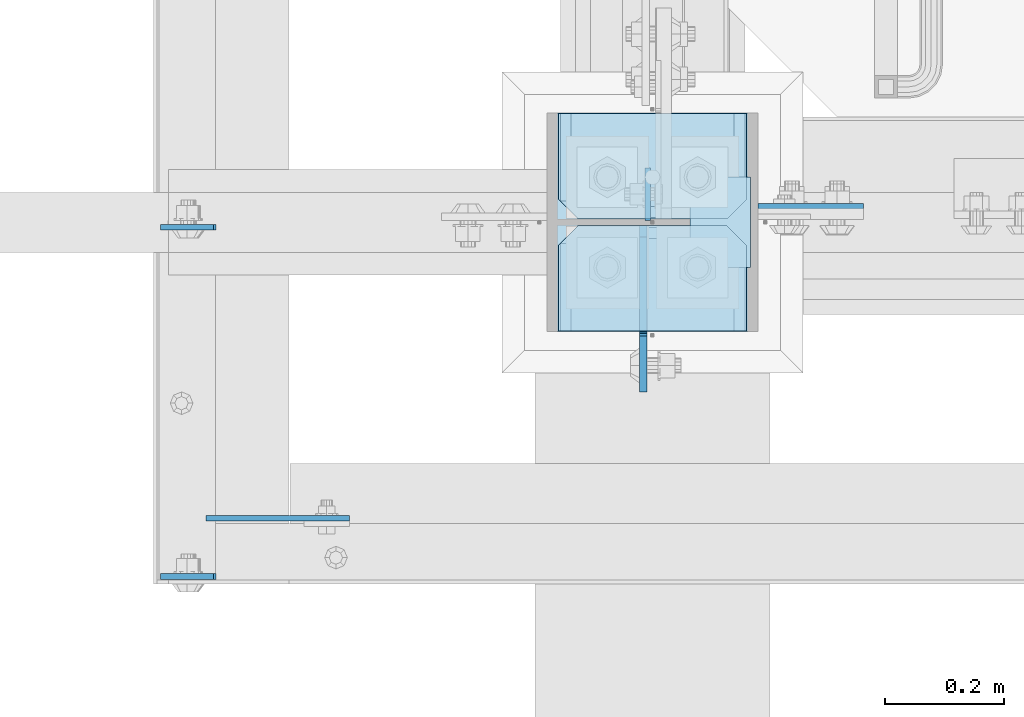
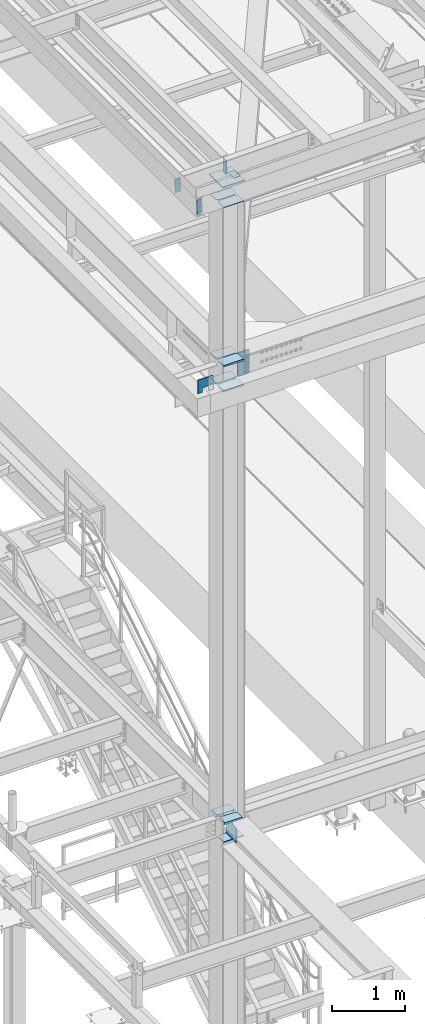
# One storey, part 3018 of 3843: 17 plates, 4 elements without a shape of their own.
"""IFC2X3 building model written with IfcOpenShell, lengths in millimetres."""

from ifc_helpers import new_model, si_unit, frame, origin_with_axes, place, context, subcontext, project, spatial, faceted_brep, material, type_object, element, aggregate, save


model = new_model("IFC2X3")

# Units and contexts
model_context = context("Model", 3, precision=1e-05, world=origin_with_axes())
body_context = subcontext(model_context, "Body", "Model", "MODEL_VIEW")
ifc_project = project(units=[si_unit("LENGTHUNIT", "METRE", prefix="MILLI"), si_unit("AREAUNIT", "SQUARE_METRE"), si_unit("VOLUMEUNIT", "CUBIC_METRE"), si_unit("MASSUNIT", "GRAM", prefix="KILO"), si_unit("TIMEUNIT", "SECOND"), si_unit("PLANEANGLEUNIT", "RADIAN"), si_unit("SOLIDANGLEUNIT", "STERADIAN"), si_unit("THERMODYNAMICTEMPERATUREUNIT", "DEGREE_CELSIUS"), si_unit("LUMINOUSINTENSITYUNIT", "LUMEN")], contexts=[model_context])

# Site, building, storey
site_placement = place(None, origin_with_axes())
site = spatial("IfcSite", under=ifc_project, at=site_placement, CompositionType="ELEMENT")
building_placement = place(site_placement, origin_with_axes())
building = spatial("IfcBuilding", under=site, at=building_placement, Name="Undefined", CompositionType="ELEMENT")
storey_placement = place(building_placement, origin_with_axes())
storey = spatial("IfcBuildingStorey", under=building, at=storey_placement, Name="Undefined", CompositionType="ELEMENT", Elevation=0.0)

# Assembly, plates
assembly_1_placement = place(storey_placement, origin_with_axes())
assembly_1 = element("IfcElementAssembly", 1, at=assembly_1_placement, inside=storey, Name="COLUMN", AssemblyPlace="NOTDEFINED", PredefinedType="RIGID_FRAME")
ifc_material = material(Name="STEEL/A572-50")
plate_type_1 = type_object("IfcPlateType", PredefinedType="NOTDEFINED")
plate_1_placement = place(assembly_1_placement, frame((36734.75, 25610.34375, 34493.2), z_axis=(-1.0, 0.0, 0.0), x_axis=(0.0, -1.0, 0.0)))
plate_1 = element("IfcPlate", 2, at=plate_1_placement, type_object=plate_type_1, material=ifc_material, Name="PLATE", context=body_context, shape_type="Brep", body=[
    faceted_brep([(0.0, -6.34999999999854, 33.3375015258789), (0.0, -6.34999999999854, 284.162498474121), (0.0, 6.34999999999854, 284.162498474121), (0.0, 6.34999999999854, 33.3375015258789), (33.3375015258789, -6.34999999999854, 317.5), (33.3375015258789, 6.34999999999854, 317.5), (177.800003051758, -6.34999999999854, 317.5), (177.800003051758, 6.34999999999854, 317.5), (177.800000000003, -6.34999999999854, 0.0), (177.800000000003, 6.34999999999854, 0.0), (33.3375015258789, -6.34999999999854, 0.0), (33.3375015258789, 6.34999999999854, 0.0)], [[[0, 1, 2, 3]], [[1, 4, 5, 2]], [[4, 6, 7, 5]], [[6, 8, 9, 7]], [[8, 10, 11, 9]], [[10, 0, 3, 11]], [[5, 7, 9, 11, 3, 2]], [[10, 8, 6, 4, 1, 0]]]),
])
plate_type_2 = type_object("IfcPlateType", PredefinedType="NOTDEFINED")
plate_2_placement = place(assembly_1_placement, frame((36734.75, 25610.34375, 42005.249987793), z_axis=(-1.0, 0.0, 0.0), x_axis=(0.0, -1.0, 0.0)))
plate_2 = element("IfcPlate", 3, at=plate_2_placement, type_object=plate_type_2, material=ifc_material, Name="PLATE", context=body_context, shape_type="Brep", body=[
    faceted_brep([(0.0, -12.6999999999971, 33.3375015258789), (0.0, -12.6999999999971, 284.162498474121), (0.0, 12.6999999999971, 284.162498474121), (0.0, 12.6999999999971, 33.3375015258789), (33.3375015258789, -12.6999999999971, 317.5), (33.3375015258789, 12.6999999999971, 317.5), (177.800003051758, -12.6999999999971, 317.5), (177.800003051758, 12.6999999999971, 317.5), (177.800003051758, -12.6999999999971, 0.0), (177.800003051758, 12.6999999999971, 0.0), (33.3375015258789, -12.6999999999971, 0.0), (33.3375015258789, 12.6999999999971, 0.0)], [[[0, 1, 2, 3]], [[1, 4, 5, 2]], [[4, 6, 7, 5]], [[6, 8, 9, 7]], [[8, 10, 11, 9]], [[10, 0, 3, 11]], [[5, 7, 9, 11, 3, 2]], [[10, 8, 6, 4, 1, 0]]]),
])
plate_3_placement = place(assembly_1_placement, frame((36734.75, 25610.34375, 42424.35), z_axis=(-1.0, 0.0, 0.0), x_axis=(0.0, -1.0, 0.0)))
plate_3 = element("IfcPlate", 4, at=plate_3_placement, type_object=plate_type_2, material=ifc_material, Name="PLATE", context=body_context, shape_type="Brep", body=[
    faceted_brep([(0.0, -12.6999999999971, 33.3375015258789), (0.0, -12.6999999999971, 284.162498474121), (0.0, 12.6999999999971, 284.162498474121), (0.0, 12.6999999999971, 33.3375015258789), (33.3375015258789, -12.6999999999971, 317.5), (33.3375015258789, 12.6999999999971, 317.5), (177.800003051758, -12.6999999999971, 317.5), (177.800003051758, 12.6999999999971, 317.5), (177.800003051758, -12.6999999999971, 0.0), (177.800003051758, 12.6999999999971, 0.0), (33.3375015258789, -12.6999999999971, 0.0), (33.3375015258789, 12.6999999999971, 0.0)], [[[0, 1, 2, 3]], [[1, 4, 5, 2]], [[4, 6, 7, 5]], [[6, 8, 9, 7]], [[8, 10, 11, 9]], [[10, 0, 3, 11]], [[5, 7, 9, 11, 3, 2]], [[10, 8, 6, 4, 1, 0]]]),
])
plate_4_placement = place(assembly_1_placement, frame((36753.8, 25634.95, 42411.65), z_axis=(1.0, 0.0, 0.0), x_axis=(0.0, 0.0, -1.0)))
plate_4 = element("IfcPlate", 5, at=plate_4_placement, type_object=plate_type_2, material=ifc_material, Name="PLATE", context=body_context, shape_type="Brep", body=[
    faceted_brep([(0.0, -12.6999999999971, 0.0), (4.36557456851006e-11, -12.7000000000171, 177.800000000003), (-1.45519152283669e-11, 12.7000000000025, 177.800000000003), (0.0, 12.6999999999971, 0.0), (393.700012207031, -12.7000000000007, 177.800003051758), (393.700012207031, 12.7000000000007, 177.800003051758), (393.700012207031, -12.7000000000007, 0.0), (393.700012207031, 12.7000000000007, 0.0)], [[[0, 1, 2, 3]], [[1, 4, 5, 2]], [[4, 6, 7, 5]], [[6, 0, 3, 7]], [[5, 7, 3, 2]], [[6, 4, 1, 0]]]),
])
plate_5_placement = place(assembly_1_placement, frame((36734.75, 25799.25625, 42005.249987793), z_axis=(-1.0, 0.0, 0.0), x_axis=(0.0, -1.0, 0.0)))
plate_5 = element("IfcPlate", 6, at=plate_5_placement, type_object=plate_type_2, material=ifc_material, Name="PLATE", context=body_context, shape_type="Brep", body=[
    faceted_brep([(0.0, -12.6999999999971, 0.0), (0.0, -12.7000000020344, 317.500000001608), (0.0, 12.6999999977998, 317.500000001586), (0.0, 12.6999999999971, 0.0), (144.462501525879, -12.6999999999971, 317.5), (144.462501525879, 12.6999999999971, 317.5), (177.800003051758, -12.6999999999971, 284.162498474121), (177.800003051758, 12.6999999999971, 284.162498474121), (177.800003051758, -12.6999999999971, 33.3375015258789), (177.800003051758, 12.6999999999971, 33.3375015258789), (144.462501525879, -12.6999999999971, 0.0), (144.462501525879, 12.6999999999971, 0.0)], [[[0, 1, 2, 3]], [[1, 4, 5, 2]], [[4, 6, 7, 5]], [[6, 8, 9, 7]], [[8, 10, 11, 9]], [[10, 0, 3, 11]], [[5, 7, 9, 11, 3, 2]], [[10, 8, 6, 4, 1, 0]]]),
])
plate_6_placement = place(assembly_1_placement, frame((36734.75, 25799.25625, 42424.35), z_axis=(-1.0, 0.0, 0.0), x_axis=(0.0, -1.0, 0.0)))
plate_6 = element("IfcPlate", 7, at=plate_6_placement, type_object=plate_type_2, material=ifc_material, Name="PLATE", context=body_context, shape_type="Brep", body=[
    faceted_brep([(0.0, -12.6999999999971, 0.0), (0.0, -12.7000000020344, 317.500000001608), (0.0, 12.6999999977998, 317.500000001586), (0.0, 12.6999999999971, 0.0), (144.462501525879, -12.6999999999971, 317.5), (144.462501525879, 12.6999999999971, 317.5), (177.800003051758, -12.6999999999971, 284.162498474121), (177.800003051758, 12.6999999999971, 284.162498474121), (177.800003051758, -12.6999999999971, 33.3375015258789), (177.800003051758, 12.6999999999971, 33.3375015258789), (144.462501525879, -12.6999999999971, 0.0), (144.462501525879, 12.6999999999971, 0.0)], [[[0, 1, 2, 3]], [[1, 4, 5, 2]], [[4, 6, 7, 5]], [[6, 8, 9, 7]], [[8, 10, 11, 9]], [[10, 0, 3, 11]], [[5, 7, 9, 11, 3, 2]], [[10, 8, 6, 4, 1, 0]]]),
])

# Assembly, plate
assembly_2_placement = place(storey_placement, origin_with_axes())
assembly_2 = element("IfcElementAssembly", 8, at=assembly_2_placement, inside=storey, Name="BEAM", AssemblyPlace="NOTDEFINED", PredefinedType="RIGID_FRAME")
plate_type_3 = type_object("IfcPlateType", PredefinedType="NOTDEFINED")
plate_7_placement = place(assembly_2_placement, frame((35746.5416189911, 25019.0000000811, 45673.9373921671), z_axis=(0.999776270257024, 0.0, 0.0211520550054619), x_axis=(0.0211520550054438, 0.0, -0.999776270257025)))
plate_7 = element("IfcPlate", 9, at=plate_7_placement, type_object=plate_type_3, material=ifc_material, Name="PLATE", context=body_context, shape_type="Brep", body=[
    faceted_brep([(0.0, -4.76249999999709, 0.0), (0.0, -4.76249999999709, 88.9000015258789), (0.0, 4.76249999999709, 88.9000015258789), (0.0, 4.76249999999709, 0.0), (228.600006102781, -4.7625000004191, 88.9000015257589), (228.600006102781, 4.76249999954598, 88.9000015257443), (228.600006103079, -4.7625000004482, 7.27595761418343e-12), (228.600006103079, 4.76249999954598, -7.27595761418343e-12)], [[[0, 1, 2, 3]], [[1, 4, 5, 2]], [[4, 6, 7, 5]], [[6, 0, 3, 7]], [[5, 7, 3, 2]], [[6, 4, 1, 0]]]),
])

assembly_3_placement = place(storey_placement, origin_with_axes())
assembly_3 = element("IfcElementAssembly", 10, at=assembly_3_placement, inside=storey, Name="BEAM", AssemblyPlace="NOTDEFINED", PredefinedType="RIGID_FRAME")
plate_8_placement = place(assembly_3_placement, frame((36568.0624999161, 25619.075, 45691.4946293701), z_axis=(0.0, 1.0, 0.0), x_axis=(0.0, 0.0, -1.0)))
plate_8 = element("IfcPlate", 11, at=plate_8_placement, type_object=plate_type_3, material=ifc_material, Name="PLATE", context=body_context, shape_type="Brep", body=[
    faceted_brep([(0.0, -4.76249999999709, 0.0), (0.0, -4.76249999999709, 88.9000015258789), (0.0, 4.76249999999709, 88.9000015258789), (0.0, 4.76249999999709, 0.0), (228.600006102781, -4.7625000004191, 88.9000015257589), (228.600006102781, 4.76249999954598, 88.9000015257443), (228.600006103079, -4.7625000004482, 7.27595761418343e-12), (228.600006103079, 4.76249999954598, -7.27595761418343e-12)], [[[0, 1, 2, 3]], [[1, 4, 5, 2]], [[4, 6, 7, 5]], [[6, 0, 3, 7]], [[5, 7, 3, 2]], [[6, 4, 1, 0]]]),
])

# Plate
plate_9_placement = place(assembly_2_placement, frame((35746.5416189907, 25607.9625, 45673.9373921793), z_axis=(0.999776270257024, 0.0, 0.0211520550054619), x_axis=(0.0211520550054438, 0.0, -0.999776270257025)))
plate_9 = element("IfcPlate", 12, at=plate_9_placement, type_object=plate_type_3, material=ifc_material, Name="PLATE", context=body_context, shape_type="Brep", body=[
    faceted_brep([(0.0, -4.76249999999709, 0.0), (0.0, -4.76249999999709, 88.9000015258789), (0.0, 4.76249999999709, 88.9000015258789), (0.0, 4.76249999999709, 0.0), (228.600006102781, -4.7625000004191, 88.9000015257589), (228.600006102781, 4.76249999954598, 88.9000015257443), (228.600006103079, -4.7625000004482, 7.27595761418343e-12), (228.600006103079, 4.76249999954598, -7.27595761418343e-12)], [[[0, 1, 2, 3]], [[1, 4, 5, 2]], [[4, 6, 7, 5]], [[6, 0, 3, 7]], [[5, 7, 3, 2]], [[6, 4, 1, 0]]]),
])

aggregate(assembly_2, [plate_7, plate_9])

plate_type_4 = type_object("IfcPlateType", PredefinedType="NOTDEFINED")
plate_10_placement = place(assembly_3_placement, frame((36639.4862641946, 25692.1000000002, 45420.5592627961), z_axis=(1.0, 0.0, 0.0), x_axis=(0.0, -1.0, 0.0)))
plate_10 = element("IfcPlate", 13, at=plate_10_placement, type_object=plate_type_4, material=ifc_material, Name="PLATE", context=body_context, shape_type="Brep", body=[
    faceted_brep([(0.0, -2.38100000000122, 0.0), (0.0, -2.38100000000122, 101.599998474121), (0.0, 2.38100000000122, 101.599998474121), (0.0, 2.38100000000122, 0.0), (152.399998474109, -2.38100000000122, 101.599998474121), (152.399998474109, 2.38100000000122, 101.599998474121), (152.399998474109, -2.38100000000122, 0.0), (152.399998474109, 2.38100000000122, 0.0)], [[[0, 1, 2, 3]], [[1, 4, 5, 2]], [[4, 6, 7, 5]], [[6, 0, 3, 7]], [[5, 7, 3, 2]], [[6, 4, 1, 0]]]),
])

aggregate(assembly_3, [plate_10, plate_8])

plate_type_5 = type_object("IfcPlateType", PredefinedType="NOTDEFINED")
plate_11_placement = place(assembly_1_placement, frame((36734.75, 25610.34375, 45070.712499999), z_axis=(-1.0, 0.0, 0.0), x_axis=(0.0, -1.0, 0.0)))
plate_11 = element("IfcPlate", 14, at=plate_11_placement, type_object=plate_type_5, material=ifc_material, Name="PLATE", context=body_context, shape_type="Brep", body=[
    faceted_brep([(0.0, -4.76249999999709, 33.3375015258789), (0.0, -4.76249999999709, 284.162498474121), (0.0, 4.76249999999709, 284.162498474121), (0.0, 4.76249999999709, 33.3375015258789), (33.3375015258789, -4.76249999999709, 317.5), (33.3375015258789, 4.76249999999709, 317.5), (177.800003051758, -4.76249999999709, 317.5), (177.800003051758, 4.76249999999709, 317.5), (177.800000000003, -4.76249999999709, -1.45519152283669e-11), (177.800000000003, 4.76249999999709, -1.45519152283669e-11), (33.3375015258789, -4.76249999999709, 0.0), (33.3375015258789, 4.76249999999709, 0.0)], [[[0, 1, 2, 3]], [[1, 4, 5, 2]], [[4, 6, 7, 5]], [[6, 8, 9, 7]], [[8, 10, 11, 9]], [[10, 0, 3, 11]], [[5, 7, 9, 11, 3, 2]], [[10, 8, 6, 4, 1, 0]]]),
])

plate_12_placement = place(assembly_1_placement, frame((36734.75, 25799.25625, 45070.712499999), z_axis=(-1.0, 0.0, 0.0), x_axis=(0.0, -1.0, 0.0)))
plate_12 = element("IfcPlate", 15, at=plate_12_placement, type_object=plate_type_5, material=ifc_material, Name="PLATE", context=body_context, shape_type="Brep", body=[
    faceted_brep([(0.0, -4.76249999999709, 0.0), (0.0, -4.76249999785796, 317.500000005042), (0.0, 4.76250000210712, 317.50000000505), (0.0, 4.76249999999709, 0.0), (144.462501525879, -4.76249999999709, 317.5), (144.462501525879, 4.76249999999709, 317.5), (177.800003051758, -4.76249999999709, 284.162498474121), (177.800003051758, 4.76249999999709, 284.162498474121), (177.800003051758, -4.76249999999709, 33.3375015258789), (177.800003051758, 4.76249999999709, 33.3375015258789), (144.462501525879, -4.76249999999709, 0.0), (144.462501525879, 4.76249999999709, 0.0)], [[[0, 1, 2, 3]], [[1, 4, 5, 2]], [[4, 6, 7, 5]], [[6, 8, 9, 7]], [[8, 10, 11, 9]], [[10, 0, 3, 11]], [[5, 7, 9, 11, 3, 2]], [[10, 8, 6, 4, 1, 0]]]),
])

plate_type_6 = type_object("IfcPlateType", PredefinedType="NOTDEFINED")
plate_13_placement = place(assembly_1_placement, frame((36417.25, 25621.45625, 34794.825), z_axis=(1.0, 0.0, 0.0), x_axis=(0.0, 1.0, 0.0)))
plate_13 = element("IfcPlate", 16, at=plate_13_placement, type_object=plate_type_6, material=ifc_material, Name="PLATE", context=body_context, shape_type="Brep", body=[
    faceted_brep([(17.7290728964945, 9.33425982176414, 269.285526505897), (21.5053709990971, 15.875, 273.0618246085), (21.5053709990898, 15.875, 44.4381753915077), (17.7290728964945, 9.33425982176414, 48.214473494103), (9.32072521071677, -5.22942557770875, 52.4987406282016), (3.174499952318, -15.875, 53.472207075858), (3.17449995232528, -15.875, 264.027792924142), (9.32072521071314, -5.22942557770875, 265.001259371798), (30.1625003814697, 15.875, 295.994129000901), (30.1625003814697, -15.875, 314.325000047669), (177.800003051758, -15.875, 314.325000047669), (177.800003051758, 15.875, 295.994129000901), (177.800003051758, 15.875, 21.5058709990699), (177.800003051758, -15.875, 3.17499995230173), (30.1625003814697, -15.875, 3.17499995230173), (30.1625003814697, 15.875, 21.5058709990699), (9.32072521071314, -15.875, 265.001259371798), (17.7290728964945, -15.875, 269.285526505897), (24.401975401448, -15.875, 275.958429010854), (24.401975401448, 15.875, 275.958429010854), (28.6862425355503, -15.875, 284.366776696632), (28.6862425355503, 15.875, 284.366776696632), (30.1625003814697, -15.875, 293.687501907349), (30.1625003814697, 15.875, 293.687501907349), (30.1625003814697, -15.875, 23.8124980926514), (30.1625003814697, 15.875, 23.8124980926514), (28.6862425355503, -15.875, 33.1332233033609), (28.6862425355503, 15.875, 33.1332233033609), (24.401975401448, -15.875, 41.5415709891386), (24.401975401448, 15.875, 41.5415709891386), (17.7290728964945, -15.875, 48.2144734940957), (9.32072521071677, -15.875, 52.4987406282016)], [[[0, 1, 2, 3, 4, 5, 6, 7]], [[8, 9, 10, 11]], [[12, 13, 14, 15]], [[16, 7, 6]], [[16, 17, 0, 7]], [[17, 18, 19, 1, 0]], [[18, 20, 21, 19]], [[20, 22, 23, 21]], [[23, 22, 9, 8]], [[13, 12, 11, 10]], [[24, 25, 15, 14]], [[24, 26, 27, 25]], [[26, 28, 29, 27]], [[29, 28, 30, 3, 2]], [[30, 31, 4, 3]], [[31, 5, 4]], [[19, 21, 23, 8, 11, 12, 15, 25, 27, 29, 2, 1]], [[31, 30, 28, 26, 24, 14, 13, 10, 9, 22, 20, 18, 17, 16, 6, 5]]]),
])

plate_14_placement = place(assembly_1_placement, frame((36417.25, 25432.54375, 34794.825), z_axis=(1.0, 0.0, 0.0), x_axis=(0.0, 1.0, 0.0)))
plate_14 = element("IfcPlate", 17, at=plate_14_placement, type_object=plate_type_6, material=ifc_material, Name="PLATE", context=body_context, shape_type="Brep", body=[
    faceted_brep([(160.070930155263, 9.33338851059671, 48.2144734940957), (156.294129000915, 15.875, 44.437675391513), (156.294129000922, 15.875, 273.062327660242), (160.070930155263, 9.33338851059671, 269.285526505897), (168.479277841041, -5.23029688887618, 265.001259371798), (174.625000047694, -15.875, 264.027872599705), (174.625000047687, -15.875, 53.4721278836369), (168.479277841041, -5.23029688887618, 52.4987406282016), (147.637500024415, 15.875, 21.5058709990408), (147.637502670288, -15.875, 3.17499995230173), (0.0, -15.875, 3.17500000000291), (0.0, 15.875, 21.5058709990699), (0.0, 15.875, 295.994129000901), (0.0, -15.875, 314.325000047669), (147.637502670288, -15.875, 314.325000047669), (147.637502670288, 15.875, 295.994129000901), (147.637502670288, -15.875, 293.687501907349), (147.637502670288, 15.875, 293.687501907349), (149.113760516204, -15.875, 284.366776696632), (149.113760516204, 15.875, 284.366776696632), (153.398027650306, -15.875, 275.958429010854), (153.398027650306, 15.875, 275.958429010854), (160.070930155263, -15.875, 269.285526505897), (168.479277841041, -15.875, 265.001259371798), (168.479274789282, -15.875, 52.4987406282016), (160.070927103505, -15.875, 48.2144734940957), (153.398024598548, -15.875, 41.5415709891386), (153.398024598548, 15.875, 41.5415709891386), (149.113757464449, -15.875, 33.1332233033609), (149.113757464449, 15.875, 33.1332233033609), (147.63749961853, -15.875, 23.8124980926514), (147.63749961853, 15.875, 23.8124980926514)], [[[0, 1, 2, 3, 4, 5, 6, 7]], [[8, 9, 10, 11]], [[12, 13, 14, 15]], [[13, 12, 11, 10]], [[16, 17, 15, 14]], [[16, 18, 19, 17]], [[18, 20, 21, 19]], [[21, 20, 22, 3, 2]], [[22, 23, 4, 3]], [[23, 5, 4]], [[24, 7, 6]], [[24, 25, 0, 7]], [[25, 26, 27, 1, 0]], [[26, 28, 29, 27]], [[28, 30, 31, 29]], [[31, 30, 9, 8]], [[27, 29, 31, 8, 11, 12, 15, 17, 19, 21, 2, 1]], [[9, 30, 28, 26, 25, 24, 6, 5, 23, 22, 20, 18, 16, 14, 13, 10]]]),
])

# Assembly, plate
assembly_4_placement = place(storey_placement, origin_with_axes())
assembly_4 = element("IfcElementAssembly", 18, at=assembly_4_placement, inside=storey, Name="GIRT", AssemblyPlace="NOTDEFINED", PredefinedType="RIGID_FRAME")
plate_type_7 = type_object("IfcPlateType", PredefinedType="NOTDEFINED")
plate_15_placement = place(assembly_4_placement, frame((35823.5250000001, 25117.4255, 42367.2000000001), z_axis=(0.0, 0.0, 1.0), x_axis=(1.0, 0.0, 0.0)))
plate_15 = element("IfcPlate", 19, at=plate_15_placement, type_object=plate_type_7, material=ifc_material, Name="PLATE", context=body_context, shape_type="Brep", body=[
    faceted_brep([(0.0, -4.76249999999709, 0.0), (0.0, -4.76249999999709, 228.599999999999), (0.0, 4.76249999999709, 228.599999999999), (0.0, 4.76249999999709, 0.0), (241.300018310547, -4.76249999999709, 228.600006103516), (241.300018310547, 4.76249999999709, 228.600006103516), (241.300018310547, -4.76249999999709, 76.1999969482422), (241.300018310547, 4.76249999999709, 76.1999969482422), (76.1999893188477, -4.76249999999709, 76.1999969482422), (76.1999893188477, 4.76249999999709, 76.1999969482422), (76.2000000012922, -4.76250000000073, 7.27595761418343e-11), (76.2000000012922, 4.76250000000073, 7.27595761418343e-11)], [[[0, 1, 2, 3]], [[1, 4, 5, 2]], [[4, 6, 7, 5]], [[6, 8, 9, 7]], [[8, 10, 11, 9]], [[10, 0, 3, 11]], [[5, 7, 9, 11, 3, 2]], [[10, 8, 6, 4, 1, 0]]]),
])
aggregate(assembly_4, [plate_15])

# Plate
plate_type_8 = type_object("IfcPlateType", PredefinedType="NOTDEFINED")
plate_16_placement = place(assembly_1_placement, frame((36753.8, 25431.75, 45408.2597628499), z_axis=(-1.0, 0.0, 0.0), x_axis=(0.0, 1.0, 0.0)))
plate_16 = element("IfcPlate", 20, at=plate_16_placement, type_object=plate_type_8, material=ifc_material, Name="PLATE", context=body_context, shape_type="Brep", body=[
    faceted_brep([(0.0, -9.52500000000146, 0.0), (0.0, -9.52500000000146, 355.599999999999), (0.0, 9.52500000000146, 355.599999999999), (0.0, 9.52500000000146, 0.0), (368.299999999945, -9.52500000000146, 355.60000002454), (368.299999999945, 9.52500000000146, 355.60000002454), (368.299999999959, -9.52500000000146, -1.45519152283669e-11), (368.299999999959, 9.52500000000146, -1.45519152283669e-11)], [[[0, 1, 2, 3]], [[1, 4, 5, 2]], [[4, 6, 7, 5]], [[6, 0, 3, 7]], [[5, 7, 3, 2]], [[6, 4, 1, 0]]]),
])

plate_type_9 = type_object("IfcPlateType", PredefinedType="NOTDEFINED")
plate_17_placement = place(assembly_1_placement, frame((36560.1249999046, 25610.34375, 34518.6), z_axis=(0.0, -0.707106781186682, 0.707106781186413), x_axis=(0.0, -0.707106781186548, -0.707106781186548)))
plate_17 = element("IfcPlate", 21, at=plate_17_placement, type_object=plate_type_9, material=ifc_material, Name="PLATE", context=body_context, shape_type="Brep", body=[
    faceted_brep([(0.0, -6.3499999046162, 0.0), (-170.624866299491, -6.34999999999854, 170.62486629949), (-170.624866299491, 6.34999999999854, 170.62486629949), (7.27595761418343e-12, 6.3499999046162, 0.0), (-170.624866299491, -6.34999999999854, 197.565634662572), (-170.624866299491, 6.34999999999854, 197.565634662572), (-58.3716647866677, -6.34999999999854, 309.818836175399), (-58.3716647866677, 6.34999999999854, 309.818836175399), (-40.411152409768, -6.34999999999854, 291.858323798499), (-40.411152409768, 6.34999999999854, 291.858323798499), (-36.2909759416143, -6.34999999999854, 289.105309898026), (-36.2909759416143, 6.34999999999854, 289.105309898026), (-31.4308964235897, -6.34999999999854, 288.138579975442), (-31.4308964235897, 6.34999999999854, 288.138579975442), (-26.5708169055506, -6.34999999999854, 289.105309898026), (-26.5708169055506, 6.34999999999854, 289.105309898026), (-22.4506404374115, -6.34999999999854, 291.858323798499), (-22.4506404374115, 6.34999999999854, 291.858323798499), (40.9724185521845, -6.34999999999854, 355.281382788088), (40.9724185521845, 6.34999999999854, 355.281382788088), (211.597284851669, -6.34999999999854, 184.656516488598), (211.597284851669, 6.34999999999854, 184.656516488598), (26.9407683632217, -6.34999999999854, 1.30967237055302e-10), (26.9407683632217, 6.34999999999854, 1.30967237055302e-10)], [[[0, 1, 2, 3]], [[1, 4, 5, 2]], [[4, 6, 7, 5]], [[6, 8, 9, 7]], [[8, 10, 11, 9]], [[10, 12, 13, 11]], [[12, 14, 15, 13]], [[14, 16, 17, 15]], [[16, 18, 19, 17]], [[18, 20, 21, 19]], [[20, 22, 23, 21]], [[22, 0, 3, 23]], [[5, 7, 9, 11, 13, 15, 17, 19, 21, 23, 3, 2]], [[22, 20, 18, 16, 14, 12, 10, 8, 6, 4, 1, 0]]]),
])

aggregate(assembly_1, [plate_11, plate_1, plate_2, plate_3, plate_13, plate_16, plate_4, plate_5, plate_6, plate_12, plate_14, plate_17])

save(model, "model.ifc")
